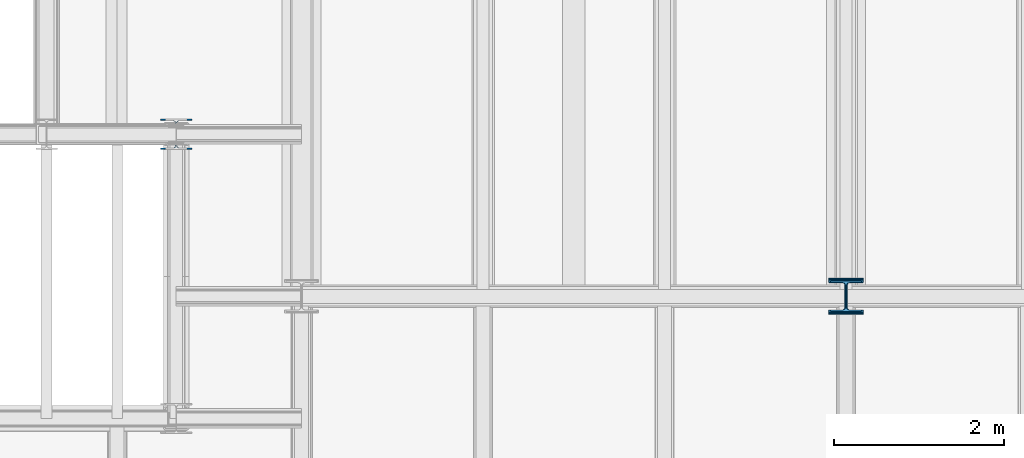
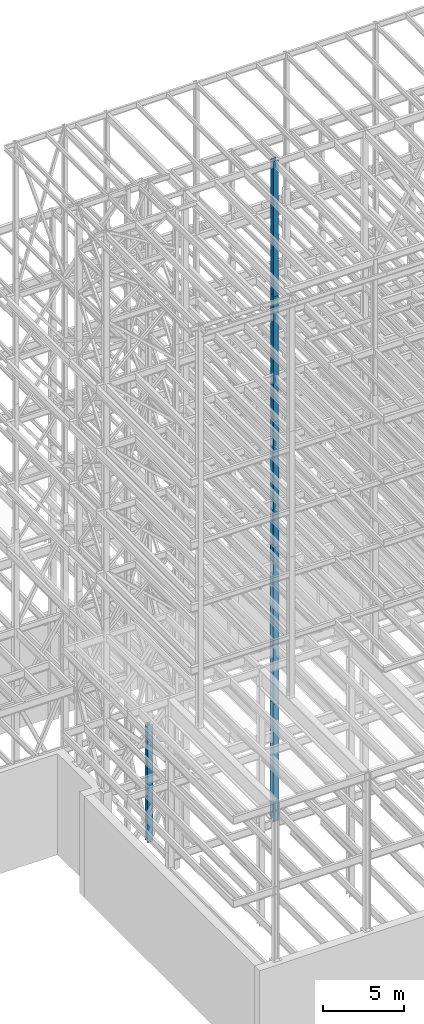
# One storey, part 18 of 150: 6 columns.
"""IFC2X3 building model written with IfcOpenShell, lengths in millimetres."""

from ifc_helpers import new_model, si_unit, frame, origin_with_axes, origin_2d_with_axis, place, context, subcontext, project, spatial, i_section, extrude, material, type_object, element, save


model = new_model("IFC2X3")

# Units and contexts
model_context = context("Model", 3, precision=1e-05, world=origin_with_axes())
body_context = subcontext(model_context, "Body", "Model", "MODEL_VIEW")
ifc_project = project(units=[si_unit("LENGTHUNIT", "METRE", prefix="MILLI"), si_unit("AREAUNIT", "SQUARE_METRE"), si_unit("VOLUMEUNIT", "CUBIC_METRE"), si_unit("MASSUNIT", "GRAM", prefix="KILO"), si_unit("TIMEUNIT", "SECOND"), si_unit("PLANEANGLEUNIT", "RADIAN"), si_unit("SOLIDANGLEUNIT", "STERADIAN"), si_unit("THERMODYNAMICTEMPERATUREUNIT", "DEGREE_CELSIUS"), si_unit("LUMINOUSINTENSITYUNIT", "LUMEN")], contexts=[model_context])

# Site, building, storey
site_placement = place(None, origin_with_axes())
site = spatial("IfcSite", under=ifc_project, at=site_placement, CompositionType="ELEMENT")
building_placement = place(site_placement, origin_with_axes())
building = spatial("IfcBuilding", under=site, at=building_placement, Name="Undefined", CompositionType="ELEMENT")
storey_placement = place(building_placement, origin_with_axes())
storey = spatial("IfcBuildingStorey", under=building, at=storey_placement, Name="Undefined", CompositionType="ELEMENT", Elevation=0.0)

# Columns
ifc_material = material(Name="STEEL/A992")
column_type_1 = type_object("IfcColumnType", Name="W14X90", PredefinedType="NOTDEFINED")
column_1_placement = place(storey_placement, frame((18186.4, 22479.0, 55702.2), z_axis=(0.0, 0.0, 1.0), x_axis=(1.0, 0.0, 0.0)))
element("IfcColumn", 1, at=column_1_placement, inside=storey, type_object=column_type_1, material=ifc_material, Name="COLUMN", ObjectType="W14X90", context=body_context, shape_type="SweptSolid", body=[
    extrude(i_section(OverallWidth=368.3, OverallDepth=355.6, WebThickness=11.1125, FlangeThickness=18.034, FilletRadius=32.7659, at=origin_2d_with_axis()), frame((0.0, 0.0, 10210.8), z_axis=(0.0, 0.0, -1.0), x_axis=(-1.0, 0.0, 0.0)), (0.0, 0.0, 1.0), 10210.8),
])
column_2_placement = place(storey_placement, frame((18186.4, 22479.0, 46253.4), z_axis=(0.0, 0.0, 1.0), x_axis=(1.0, 0.0, 0.0)))
element("IfcColumn", 2, at=column_2_placement, inside=storey, type_object=column_type_1, material=ifc_material, Name="COLUMN", ObjectType="W14X90", context=body_context, shape_type="SweptSolid", body=[
    extrude(i_section(OverallWidth=368.3, OverallDepth=355.6, WebThickness=11.1125, FlangeThickness=18.034, FilletRadius=32.7659, at=origin_2d_with_axis()), frame((0.0, 0.0, 9448.8), z_axis=(0.0, 0.0, -1.0), x_axis=(-1.0, 0.0, 0.0)), (0.0, 0.0, 1.0), 9448.8),
])
column_3_placement = place(storey_placement, frame((10312.39949708, 24384.0, 16154.4), z_axis=(0.0, 0.0, 1.0), x_axis=(1.0, 0.0, 0.0)))
element("IfcColumn", 3, at=column_3_placement, inside=storey, type_object=column_type_1, material=ifc_material, Name="COLUMN", ObjectType="W14X90", context=body_context, shape_type="SweptSolid", body=[
    extrude(i_section(OverallWidth=368.3, OverallDepth=355.6, WebThickness=11.1125, FlangeThickness=18.034, FilletRadius=32.7659, at=origin_2d_with_axis()), frame((0.0, 0.0, 8839.2), z_axis=(0.0, 0.0, -1.0), x_axis=(-1.0, 0.0, 0.0)), (0.0, 0.0, 1.0), 8839.2),
])
column_type_2 = type_object("IfcColumnType", Name="W14X233", PredefinedType="NOTDEFINED")
column_4_placement = place(storey_placement, frame((18186.4, 22479.0, 24993.6), z_axis=(0.0, 0.0, 1.0), x_axis=(1.0, 0.0, 0.0)))
element("IfcColumn", 4, at=column_4_placement, inside=storey, type_object=column_type_2, material=ifc_material, Name="COLUMN", ObjectType="W14X233", context=body_context, shape_type="SweptSolid", body=[
    extrude(i_section(OverallWidth=403.86, OverallDepth=406.4, WebThickness=26.9875, FlangeThickness=43.688, FilletRadius=32.512, at=origin_2d_with_axis()), frame((0.0, 0.0, 11811.0), z_axis=(0.0, 0.0, -1.0), x_axis=(-1.0, 0.0, 0.0)), (0.0, 0.0, 1.0), 11811.0),
])
column_type_3 = type_object("IfcColumnType", Name="W14X159", PredefinedType="NOTDEFINED")
column_5_placement = place(storey_placement, frame((18186.4, 22479.0, 36804.6), z_axis=(0.0, 0.0, 1.0), x_axis=(1.0, 0.0, 0.0)))
element("IfcColumn", 5, at=column_5_placement, inside=storey, type_object=column_type_3, material=ifc_material, Name="COLUMN", ObjectType="W14X159", context=body_context, shape_type="SweptSolid", body=[
    extrude(i_section(OverallWidth=396.24, OverallDepth=381.0, WebThickness=19.0499, FlangeThickness=30.226, FilletRadius=33.2739, at=origin_2d_with_axis()), frame((0.0, 0.0, 9448.8), z_axis=(0.0, 0.0, -1.0), x_axis=(-1.0, 0.0, 0.0)), (0.0, 0.0, 1.0), 9448.8),
])
column_type_4 = type_object("IfcColumnType", Name="W14X283", PredefinedType="NOTDEFINED")
column_6_placement = place(storey_placement, frame((18186.4, 22479.0, 16154.4), z_axis=(0.0, 0.0, 1.0), x_axis=(1.0, 0.0, 0.0)))
element("IfcColumn", 6, at=column_6_placement, inside=storey, type_object=column_type_4, material=ifc_material, Name="COLUMN", ObjectType="W14X283", context=body_context, shape_type="SweptSolid", body=[
    extrude(i_section(OverallWidth=408.94, OverallDepth=425.45, WebThickness=33.3375, FlangeThickness=52.578, FilletRadius=33.1469, at=origin_2d_with_axis()), frame((0.0, 0.0, 8839.2), z_axis=(0.0, 0.0, -1.0), x_axis=(-1.0, 0.0, 0.0)), (0.0, 0.0, 1.0), 8839.2),
])

save(model, "model.ifc")
